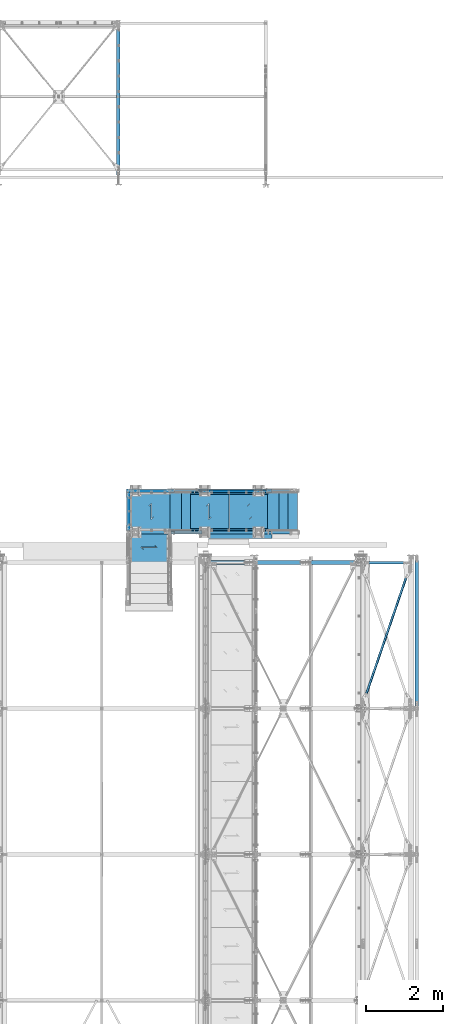
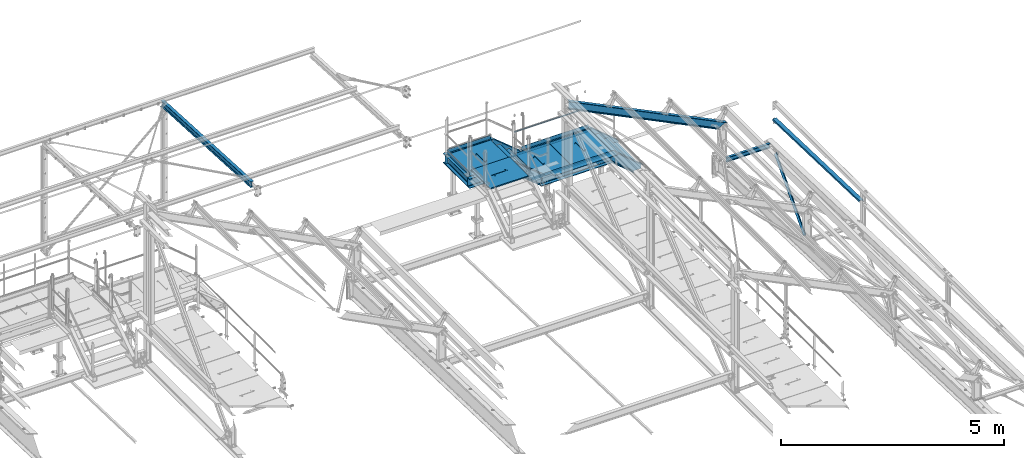
# One storey, part 58 of 496: 25 beams, 5 members, 22 elements without a shape of their own.
"""IFC2X3 building model written with IfcOpenShell, lengths in millimetres."""

import ifcopenshell
import ifcopenshell.guid

model = None  # the IFC model being written
_history = None  # IfcOwnerHistory: only IFC2X3 demands one
_inside = {}  # id of a spatial element -> (the spatial element, [elements in it])
_under = {}  # id of a project, library or spatial element -> (it, [spatial elements below it])
_declared = {}  # id of a project -> (the project, [libraries it declares])
_typed = {}  # id of a type object -> (the type object, [elements of that type])
_made_of = {}  # id of a material, layer set ... -> (it, [elements and type objects made of it])


def new_model(schema):
    """Start an empty IFC model of exactly this schema.

    Asked for "IFC4X3", IfcOpenShell would pick the latest addendum, in which some entities
    have other attributes; the version numbers below select the first issue.
    IFC2X3 requires an IfcOwnerHistory on every rooted entity: one is made here for all.
    """
    global model, _history
    if schema == "IFC4X3":
        model = ifcopenshell.file(schema_version=(4, 3, 0, 0))
    else:
        model = ifcopenshell.file(schema=schema)
    _inside.clear()
    _under.clear()
    _declared.clear()
    _typed.clear()
    _made_of.clear()
    _history = None
    if model.schema == "IFC2X3":
        org = make("IfcOrganization", Name="unknown")
        user = make(
            "IfcPersonAndOrganization",
            ThePerson=make("IfcPerson", FamilyName="unknown"),
            TheOrganization=org,
        )
        app = make(
            "IfcApplication",
            ApplicationDeveloper=org,
            Version="unknown",
            ApplicationFullName="unknown",
            ApplicationIdentifier="unknown",
        )
        _history = make(
            "IfcOwnerHistory",
            OwningUser=user,
            OwningApplication=app,
            ChangeAction="ADDED",
            CreationDate=0,
        )
    return model


def make(cls, **values):
    """One entity of the class cls with the attributes given. An attribute that is None is left unset."""
    return model.create_entity(
        cls, **{name: value for name, value in values.items() if value is not None}
    )


def rooted(cls, **values):
    """An entity with a GlobalId (a new one), such as an element, a storey or a relation."""
    return make(cls, GlobalId=ifcopenshell.guid.new(), OwnerHistory=_history, **values)


def si_unit(unit_type, name, prefix=None):
    """IfcSIUnit, for example si_unit("LENGTHUNIT", "METRE", prefix="MILLI")."""
    return make("IfcSIUnit", UnitType=unit_type, Prefix=prefix, Name=name)


def assignment(units):
    """IfcUnitAssignment: the units of a project."""
    return None if units is None else make("IfcUnitAssignment", Units=units)


def point(xyz):
    """IfcCartesianPoint."""
    return None if xyz is None else make("IfcCartesianPoint", Coordinates=xyz)


def direction(xyz):
    """IfcDirection."""
    return None if xyz is None else make("IfcDirection", DirectionRatios=xyz)


def frame(location, z_axis=None, x_axis=None):
    """IfcAxis2Placement3D, a coordinate frame: its origin and axes. An axis left out is left unset."""
    return make(
        "IfcAxis2Placement3D",
        Location=point(location),
        Axis=direction(z_axis),
        RefDirection=direction(x_axis),
    )


def frame_2d(location, x_axis=None):
    """IfcAxis2Placement2D, a coordinate frame in the plane: its origin and x axis."""
    return make(
        "IfcAxis2Placement2D", Location=point(location), RefDirection=direction(x_axis)
    )


def origin_with_axes():
    """The frame at (0, 0, 0) with the z axis (0, 0, 1) and the x axis (1, 0, 0) written out."""
    return frame((0.0, 0.0, 0.0), z_axis=(0.0, 0.0, 1.0), x_axis=(1.0, 0.0, 0.0))


def origin_2d_with_axis():
    """The frame at (0, 0) in the plane with the x axis (1, 0) written out."""
    return frame_2d((0.0, 0.0), x_axis=(1.0, 0.0))


def place(relative_to, where):
    """IfcLocalPlacement: puts the frame where relative to a parent placement (None: the world)."""
    return make(
        "IfcLocalPlacement", PlacementRelTo=relative_to, RelativePlacement=where
    )


def context(
    kind, dimensions, precision=None, world=None, true_north=None, identifier=None
):
    """IfcGeometricRepresentationContext, for example the 3D "Model" context."""
    return make(
        "IfcGeometricRepresentationContext",
        ContextIdentifier=identifier,
        ContextType=kind,
        CoordinateSpaceDimension=dimensions,
        Precision=precision,
        WorldCoordinateSystem=world,
        TrueNorth=true_north,
    )


def subcontext(parent, identifier, kind, view, scale=None):
    """IfcGeometricRepresentationSubContext, for example "Body" below "Model"."""
    return make(
        "IfcGeometricRepresentationSubContext",
        ContextIdentifier=identifier,
        ContextType=kind,
        ParentContext=parent,
        TargetScale=scale,
        TargetView=view,
    )


def project(units=None, contexts=None):
    """IfcProject with its units and contexts."""
    return rooted(
        "IfcProject",
        Name="project",
        RepresentationContexts=contexts,
        UnitsInContext=assignment(units),
    )


def spatial(cls, under=None, at=None, **own):
    """A site, building, storey or space (cls), placed at a placement, below another one or the project."""
    s = rooted(cls, ObjectPlacement=at, **own)
    if under is not None:
        _under.setdefault(under.id(), (under, []))[1].append(s)
    return s


def polyline(points):
    """IfcPolyline through the points."""
    return make("IfcPolyline", Points=[point(p) for p in points])


def profile(cls, at=None, kind="AREA", **sizes):
    """A parametric profile (cls). Its sizes go by their IFC names, for example OverallWidth=200.0."""
    return make(cls, ProfileType=kind, Position=at, **sizes)


def rectangle(**sizes):
    """IfcRectangleProfileDef."""
    return profile("IfcRectangleProfileDef", **sizes)


def hollow_circle(**sizes):
    """IfcCircleHollowProfileDef."""
    return profile("IfcCircleHollowProfileDef", **sizes)


def i_section(**sizes):
    """IfcIShapeProfileDef."""
    return profile("IfcIShapeProfileDef", **sizes)


def l_section(**sizes):
    """IfcLShapeProfileDef."""
    return profile("IfcLShapeProfileDef", **sizes)


def u_section(**sizes):
    """IfcUShapeProfileDef."""
    return profile("IfcUShapeProfileDef", **sizes)


def outline(outer, holes=None, kind="AREA"):
    """IfcArbitraryClosedProfileDef: a profile drawn as a closed curve; with holes, ...WithVoids."""
    if holes is None:
        return make("IfcArbitraryClosedProfileDef", ProfileType=kind, OuterCurve=outer)
    return make(
        "IfcArbitraryProfileDefWithVoids",
        ProfileType=kind,
        OuterCurve=outer,
        InnerCurves=holes,
    )


def extrude(swept, where, along, depth):
    """IfcExtrudedAreaSolid: the profile swept, set in the frame where, extruded along a direction by depth."""
    return make(
        "IfcExtrudedAreaSolid",
        SweptArea=swept,
        Position=where,
        ExtrudedDirection=direction(along),
        Depth=depth,
    )


def boolean(op, a, b):
    """IfcBooleanResult of two solids."""
    return make("IfcBooleanResult", Operator=op, FirstOperand=a, SecondOperand=b)


def clip(a, b, op="DIFFERENCE"):
    """IfcBooleanClippingResult: the solid a cut by the half space b."""
    return make(
        "IfcBooleanClippingResult", Operator=op, FirstOperand=a, SecondOperand=b
    )


def halfspace(plane, agree):
    """IfcHalfSpaceSolid: all space on one side of the plane z = 0 of the frame plane."""
    return make(
        "IfcHalfSpaceSolid",
        BaseSurface=make("IfcPlane", Position=plane),
        AgreementFlag=agree,
    )


def shape(context_of_items, identifier, shape_type, items):
    """IfcShapeRepresentation: the items that make up one representation, for example the "Body"."""
    return make(
        "IfcShapeRepresentation",
        ContextOfItems=context_of_items,
        RepresentationIdentifier=identifier,
        RepresentationType=shape_type,
        Items=items,
    )


def material(Name=None, Category=None):
    """IfcMaterial."""
    return make("IfcMaterial", Name=Name, Category=Category)


def made_of(thing, what):
    """Note that an element or type object is made of a material, layer set ...; save() writes the relation."""
    if what is not None:
        _made_of.setdefault(what.id(), (what, []))[1].append(thing)
    return thing


def type_object(cls, material=None, **own):
    """A type object (cls), such as IfcWallType, which elements share."""
    return made_of(rooted(cls, **own), material)


def element(
    cls,
    number,
    at=None,
    inside=None,
    cuts=None,
    type_object=None,
    material=None,
    context=None,
    identifier="Body",
    shape_type=None,
    held_by="IfcProductDefinitionShape",
    body=None,
    shapes=None,
    **own,
):
    """One element of the class cls, such as IfcWall. Its Tag is "e" and its number.

    at: its placement. inside: the storey or other place that contains it. cuts: it is an
    opening in that element (IfcRelVoidsElement). A single representation is given by context,
    identifier, shape_type and body (its items); several are given by shapes. held_by: the class
    of the entity that holds the representations. save() writes the other relations.
    """
    e = rooted(cls, Tag="e%d" % number, ObjectPlacement=at, **own)
    if body is not None:
        shapes = [shape(context, identifier, shape_type, body)]
    if shapes is not None:
        e.Representation = make(held_by, Representations=shapes)
    if inside is not None:
        _inside.setdefault(inside.id(), (inside, []))[1].append(e)
    if cuts is not None:
        rooted(
            "IfcRelVoidsElement", RelatingBuildingElement=cuts, RelatedOpeningElement=e
        )
    if type_object is not None:
        _typed.setdefault(type_object.id(), (type_object, []))[1].append(e)
    return made_of(e, material)


def aggregate(whole, parts):
    """IfcRelAggregates: a whole, such as a stair, and the parts it consists of."""
    return rooted("IfcRelAggregates", RelatingObject=whole, RelatedObjects=parts)


def save(model, path):
    """Write the relations noted so far, then the file.

    IfcRelAggregates (storeys below a building ...), IfcRelContainedInSpatialStructure (elements
    in a storey), IfcRelDefinesByType, IfcRelAssociatesMaterial and IfcRelDeclares: one each for
    every whole, place, type object, material and project.
    """
    for whole, parts in _under.values():
        aggregate(whole, parts)
    for where, things in _inside.values():
        rooted(
            "IfcRelContainedInSpatialStructure",
            RelatedElements=things,
            RelatingStructure=where,
        )
    for kind, things in _typed.values():
        rooted("IfcRelDefinesByType", RelatedObjects=things, RelatingType=kind)
    for what, things in _made_of.values():
        rooted("IfcRelAssociatesMaterial", RelatedObjects=things, RelatingMaterial=what)
    for by, libraries in _declared.values():
        rooted("IfcRelDeclares", RelatingContext=by, RelatedDefinitions=libraries)
    model.write(path)


model = new_model("IFC2X3")

# Units and contexts
model_context = context("Model", 3, precision=1e-05, world=origin_with_axes())
body_context = subcontext(model_context, "Body", "Model", "MODEL_VIEW")
ifc_project = project(units=[si_unit("LENGTHUNIT", "METRE", prefix="MILLI"), si_unit("AREAUNIT", "SQUARE_METRE"), si_unit("VOLUMEUNIT", "CUBIC_METRE"), si_unit("MASSUNIT", "GRAM", prefix="KILO"), si_unit("TIMEUNIT", "SECOND"), si_unit("PLANEANGLEUNIT", "RADIAN"), si_unit("SOLIDANGLEUNIT", "STERADIAN"), si_unit("THERMODYNAMICTEMPERATUREUNIT", "DEGREE_CELSIUS"), si_unit("LUMINOUSINTENSITYUNIT", "LUMEN")], contexts=[model_context])

# Site, building, storey
site_placement = place(None, origin_with_axes())
site = spatial("IfcSite", under=ifc_project, at=site_placement, CompositionType="ELEMENT")
building_placement = place(site_placement, origin_with_axes())
building = spatial("IfcBuilding", under=site, at=building_placement, Name="Undefined", CompositionType="ELEMENT")
storey_placement = place(building_placement, origin_with_axes())
storey = spatial("IfcBuildingStorey", under=building, at=storey_placement, Name="Undefined", CompositionType="ELEMENT", Elevation=0.0)

# Assembly, beam
assembly_1_placement = place(storey_placement, origin_with_axes())
assembly_1 = element("IfcElementAssembly", 1, at=assembly_1_placement, inside=storey, Name="VIDE", AssemblyPlace="NOTDEFINED", PredefinedType="NOTDEFINED")
ifc_material_1 = material(Name="Undefined/S235-E24")
beam_type_1 = type_object("IfcBeamType", PredefinedType="NOTDEFINED")
beam_1_placement = place(assembly_1_placement, frame((36000.0099902533, 15929.9998774163, 8112.9999407383), z_axis=(0.0, -1.0, 0.0), x_axis=(-1.0, 0.0, 0.0)))
beam_1 = element("IfcBeam", 2, at=beam_1_placement, type_object=beam_type_1, material=ifc_material_1, Name="VIDE", context=body_context, shape_type="SweptSolid", body=[
    extrude(rectangle(XDim=6.0, YDim=200.0, at=origin_2d_with_axis()), frame((1650.0, 0.0, 0.0), z_axis=(-1.0, 0.0, 0.0), x_axis=(0.0, -1.0, 0.0)), (0.0, 0.0, 1.0), 1650.0),
])
aggregate(assembly_1, [beam_1])

# Assembly, beams
assembly_2_placement = place(storey_placement, origin_with_axes())
assembly_2 = element("IfcElementAssembly", 3, at=assembly_2_placement, inside=storey, Name="MAIN COURANTE", AssemblyPlace="NOTDEFINED", PredefinedType="NOTDEFINED")
beam_type_2 = type_object("IfcBeamType", PredefinedType="NOTDEFINED")
beam_2_placement = place(assembly_2_placement, frame((34050.3145397259, 17089.9937511109, 8653.80000001012), z_axis=(0.0, 1.0, 0.0), x_axis=(1.0, 0.0, 0.0)))
beam_2 = element("IfcBeam", 4, at=beam_2_placement, type_object=beam_type_2, material=ifc_material_1, Name="LISSE", context=body_context, shape_type="Clipping", body=[
    clip(clip(extrude(hollow_circle(Radius=10.64999962, WallThickness=2.0, at=origin_2d_with_axis()), frame((1828.74844172951, -1.81898940354586e-12, 0.0), z_axis=(-1.0, 0.0, 0.0), x_axis=(0.0, -1.0, 0.0)), (0.0, 0.0, 1.0), 1836.49), halfspace(frame((1821.00987948852, 4.36557456851006e-10, -0.00100506085436791), z_axis=(0.940271589914334, 0.340425229969278, -5.78267025161579e-07), x_axis=(0.0, 0.0, 1.0)), False)), halfspace(frame((3.80609846943116, -10.6499996200018, 0.000112519468530081), z_axis=(0.941671113820088, 0.336534564935759, -5.79127732359695e-07), x_axis=(0.0, 0.0, 1.0)), True)),
])
beam_type_3 = type_object("IfcBeamType", PredefinedType="NOTDEFINED")
beam_3_placement = place(assembly_2_placement, frame((35944.9962475594, 17057.481480291, 8170.00000001012), z_axis=(0.0, 0.0, -1.0), x_axis=(-1.0, 0.0, 0.0)))
beam_3 = element("IfcBeam", 5, at=beam_3_placement, type_object=beam_type_3, material=ifc_material_1, context=body_context, shape_type="SweptSolid", body=[
    extrude(rectangle(XDim=5.0, YDim=100.0, at=origin_2d_with_axis()), frame((1734.99407492106, 0.0, 0.0), z_axis=(-1.0, 0.0, 0.0), x_axis=(0.0, -1.0, 0.0)), (0.0, 0.0, 1.0), 1734.99),
])
beam_4_placement = place(assembly_2_placement, frame((33404.9962475594, 17057.481480291, 8760.00000001012), z_axis=(0.0, 0.0, -1.0), x_axis=(-1.0, 0.0, 0.0)))
beam_4 = element("IfcBeam", 6, at=beam_4_placement, type_object=beam_type_3, material=ifc_material_1, context=body_context, shape_type="SweptSolid", body=[
    extrude(rectangle(XDim=5.0, YDim=100.0, at=origin_2d_with_axis()), frame((1100.00006264001, 0.0, 0.0), z_axis=(-1.0, 0.0, 0.0), x_axis=(0.0, -1.0, 0.0)), (0.0, 0.0, 1.0), 1100.0),
])
aggregate(assembly_2, [beam_2, beam_3, beam_4])

# Assembly, beam
assembly_3_placement = place(storey_placement, origin_with_axes())
assembly_3 = element("IfcElementAssembly", 7, at=assembly_3_placement, inside=storey, Name="MAIN COURANTE", AssemblyPlace="NOTDEFINED", PredefinedType="NOTDEFINED")
beam_5_placement = place(assembly_3_placement, frame((32282.4987221813, 17044.9977309424, 8760.00000001012), z_axis=(0.0, 0.0, -1.0), x_axis=(0.0, -1.0, 0.0)))
beam_5 = element("IfcBeam", 8, at=beam_5_placement, type_object=beam_type_3, material=ifc_material_1, context=body_context, shape_type="SweptSolid", body=[
    extrude(rectangle(XDim=5.0, YDim=100.0, at=origin_2d_with_axis()), frame((1009.99407492107, 0.0, 0.0), z_axis=(-1.0, 0.0, 0.0), x_axis=(0.0, -1.0, 0.0)), (0.0, 0.0, 1.0), 1009.99),
])
aggregate(assembly_3, [beam_5])

assembly_4_placement = place(storey_placement, origin_with_axes())
assembly_4 = element("IfcElementAssembly", 9, at=assembly_4_placement, inside=storey, Name="PALIER", AssemblyPlace="NOTDEFINED", PredefinedType="NOTDEFINED")
beam_type_4 = type_object("IfcBeamType", PredefinedType="NOTDEFINED")
beam_6_placement = place(assembly_4_placement, frame((35944.9999902344, 16530.0012856021, 8094.9999407569), z_axis=(0.0, 1.0, 0.0), x_axis=(-1.0, 0.0, 0.0)))
beam_6 = element("IfcBeam", 10, at=beam_6_placement, type_object=beam_type_4, material=ifc_material_1, Name="PALIER", context=body_context, shape_type="CSG", body=[
    boolean("DIFFERENCE", extrude(rectangle(XDim=30.0, YDim=990.0, at=origin_2d_with_axis()), frame((1050.0, 0.0, 0.0), z_axis=(-1.0, 0.0, 0.0), x_axis=(0.0, -1.0, 0.0)), (0.0, 0.0, 1.0), 1050.0), extrude(outline(polyline([(0.0, 0.0), (87.0678024292865, -7.27595761418343e-12), (-195.774902343946, 282.842712402629), (-132.842712402475, 282.842712402631), (-132.842712402482, 292.84271240264), (-219.917037964085, 292.84271240264), (62.9256706238448, 10.0000000000091), (-1.81898940354586e-10, 10.0000000000073), (0.0, 0.0)])), frame((468.433764126472, 17.5, -150.504124684554), z_axis=(0.0, -1.0, 0.0), x_axis=(0.707106781186548, 0.0, -0.707106781186548)), (0.0, 0.0, 1.0), 35.0)),
])
aggregate(assembly_4, [beam_6])

assembly_5_placement = place(storey_placement, origin_with_axes())
assembly_5 = element("IfcElementAssembly", 11, at=assembly_5_placement, inside=storey, Name="PALIER", AssemblyPlace="NOTDEFINED", PredefinedType="NOTDEFINED")
beam_7_placement = place(assembly_5_placement, frame((33404.9999902344, 16530.0012856021, 8685.0), z_axis=(0.0, 1.0, 0.0), x_axis=(-1.0, 0.0, 0.0)))
beam_7 = element("IfcBeam", 12, at=beam_7_placement, type_object=beam_type_4, material=ifc_material_1, Name="PALIER", context=body_context, shape_type="CSG", body=[
    boolean("DIFFERENCE", extrude(rectangle(XDim=30.0, YDim=990.0, at=origin_2d_with_axis()), frame((1090.0, 0.0, 0.0), z_axis=(-1.0, 0.0, 0.0), x_axis=(0.0, -1.0, 0.0)), (0.0, 0.0, 1.0), 1090.0), extrude(outline(polyline([(0.0, 0.0), (87.0678024292865, -7.27595761418343e-12), (-195.774902343946, 282.842712402629), (-132.842712402475, 282.842712402631), (-132.842712402482, 292.84271240264), (-219.917037964085, 292.84271240264), (62.9256706238448, 10.0000000000091), (-1.81898940354586e-10, 10.0000000000073), (0.0, 0.0)])), frame((488.433762432338, 17.4998126435639, -150.504124684554), z_axis=(0.0, -1.0, 0.0), x_axis=(0.707106781186548, 0.0, -0.707106781186548)), (0.0, 0.0, 1.0), 35.0)),
])
aggregate(assembly_5, [beam_7])

assembly_6_placement = place(storey_placement, origin_with_axes())
assembly_6 = element("IfcElementAssembly", 13, at=assembly_6_placement, inside=storey, Name="PALIER", AssemblyPlace="NOTDEFINED", PredefinedType="NOTDEFINED")
beam_8_placement = place(assembly_6_placement, frame((34884.9999902344, 16530.0012856021, 8094.9999407569), z_axis=(0.0, 1.0, 0.0), x_axis=(-1.0, 0.0, 0.0)))
beam_8 = element("IfcBeam", 14, at=beam_8_placement, type_object=beam_type_4, material=ifc_material_1, Name="PALIER", context=body_context, shape_type="CSG", body=[
    boolean("DIFFERENCE", extrude(rectangle(XDim=30.0, YDim=990.0, at=origin_2d_with_axis()), frame((1050.0, 0.0, 0.0), z_axis=(-1.0, 0.0, 0.0), x_axis=(0.0, -1.0, 0.0)), (0.0, 0.0, 1.0), 1050.0), extrude(outline(polyline([(0.0, 0.0), (87.0678024292865, -7.27595761418343e-12), (-195.774902343946, 282.842712402629), (-132.842712402475, 282.842712402631), (-132.842712402482, 292.84271240264), (-219.917037964085, 292.84271240264), (62.9256706238448, 10.0000000000091), (-1.81898940354586e-10, 10.0000000000073), (0.0, 0.0)])), frame((468.433764126472, 17.5, -150.504124684554), z_axis=(0.0, -1.0, 0.0), x_axis=(0.707106781186548, 0.0, -0.707106781186548)), (0.0, 0.0, 1.0), 35.0)),
])
aggregate(assembly_6, [beam_8])

assembly_7_placement = place(storey_placement, origin_with_axes())
assembly_7 = element("IfcElementAssembly", 15, at=assembly_7_placement, inside=storey, Name="PALIER", AssemblyPlace="NOTDEFINED", PredefinedType="NOTDEFINED")
beam_9_placement = place(assembly_7_placement, frame((32809.9938089558, 16020.0036221498, 8865.0), z_axis=(-1.0, 0.0, 0.0), x_axis=(0.0, -1.0, 0.0)))
beam_9 = element("IfcBeam", 16, at=beam_9_placement, type_object=beam_type_4, material=ifc_material_1, Name="PALIER", context=body_context, shape_type="CSG", body=[
    boolean("DIFFERENCE", extrude(rectangle(XDim=30.0, YDim=990.0, at=origin_2d_with_axis()), frame((845.00383109971, 0.0, 0.0), z_axis=(-1.0, 0.0, 0.0), x_axis=(0.0, -1.0, 0.0)), (0.0, 0.0, 1.0), 845.0), extrude(outline(polyline([(0.0, 0.0), (87.0678024292865, -7.27595761418343e-12), (-195.774902343946, 282.842712402629), (-132.842712402475, 282.842712402631), (-132.842712402482, 292.84271240264), (-219.917037964085, 292.84271240264), (62.9256706238448, 10.0000000000091), (-1.81898940354586e-10, 10.0000000000073), (0.0, 0.0)])), frame((365.940460299036, 17.4998126435639, -150.5094572854), z_axis=(0.0, -1.0, 0.0), x_axis=(0.707106781186548, 0.0, -0.707106781186548)), (0.0, 0.0, 1.0), 35.0)),
])
aggregate(assembly_7, [beam_9])

assembly_8_placement = place(storey_placement, origin_with_axes())
assembly_8 = element("IfcElementAssembly", 17, at=assembly_8_placement, inside=storey, Name="SUPPORT", AssemblyPlace="NOTDEFINED", PredefinedType="NOTDEFINED")
beam_type_5 = type_object("IfcBeamType", PredefinedType="NOTDEFINED")
beam_10_placement = place(assembly_8_placement, frame((35894.9999902344, 17004.9999136338, 8054.9999407569), z_axis=(0.0, 0.0, -1.0), x_axis=(-1.0, 0.0, 0.0)))
beam_10 = element("IfcBeam", 18, at=beam_10_placement, type_object=beam_type_5, material=ifc_material_1, Name="SUPPORT", context=body_context, shape_type="SweptSolid", body=[
    extrude(l_section(Depth=50.0, Width=50.0, Thickness=5.0, FilletRadius=7.0, EdgeRadius=3.5, at=origin_2d_with_axis()), frame((2009.99999989913, 0.0, 0.0), z_axis=(-1.0, 0.0, 0.0), x_axis=(0.0, -1.0, 0.0)), (0.0, 0.0, 1.0), 2010.0),
])
aggregate(assembly_8, [beam_10])

assembly_9_placement = place(storey_placement, origin_with_axes())
assembly_9 = element("IfcElementAssembly", 19, at=assembly_9_placement, inside=storey, Name="SUPPORT", AssemblyPlace="NOTDEFINED", PredefinedType="NOTDEFINED")
beam_11_placement = place(assembly_9_placement, frame((33884.9999903353, 16054.9996684663, 8054.9999407569), z_axis=(0.0, 0.0, -1.0), x_axis=(1.0, 0.0, 0.0)))
beam_11 = element("IfcBeam", 20, at=beam_11_placement, type_object=beam_type_5, material=ifc_material_1, Name="SUPPORT", context=body_context, shape_type="SweptSolid", body=[
    extrude(l_section(Depth=50.0, Width=50.0, Thickness=5.0, FilletRadius=7.0, EdgeRadius=3.5, at=origin_2d_with_axis()), frame((2009.99999989913, 0.0, 0.0), z_axis=(-1.0, 0.0, 0.0), x_axis=(0.0, -1.0, 0.0)), (0.0, 0.0, 1.0), 2010.0),
])
aggregate(assembly_9, [beam_11])

# Assembly, member
assembly_10_placement = place(storey_placement, origin_with_axes())
assembly_10 = element("IfcElementAssembly", 21, at=assembly_10_placement, inside=storey, AssemblyPlace="NOTDEFINED", PredefinedType="NOTDEFINED")
ifc_material_2 = material(Name="Undefined/S275-E28")
member_type_1 = type_object("IfcMemberType", Name="UPN260", PredefinedType="NOTDEFINED")
member_1_placement = place(assembly_10_placement, frame((34103.6359782149, 15984.9996684876, 8009.44650543934), z_axis=(-0.63380948681209, 0.0, -0.77348919477068), x_axis=(-0.773488973625643, 0.0, 0.633809756693245)))
member_1 = element("IfcMember", 22, at=member_1_placement, type_object=member_type_1, material=ifc_material_2, ObjectType="UPN260", context=body_context, shape_type="Clipping", body=[
    clip(clip(extrude(u_section(Depth=260.0, FlangeWidth=90.0, WebThickness=10.0, FlangeThickness=14.0, FilletRadius=14.0, EdgeRadius=7.0, FlangeSlope=0.0798299857122373, at=origin_2d_with_axis()), frame((1123.44862759556, -1.81898940354586e-12, 0.0), z_axis=(-1.0, 0.0, 0.0), x_axis=(0.0, -1.0, 0.0)), (0.0, 0.0, 1.0), 1408.94), halfspace(frame((930.878776339017, 45.006178684931, -130.000000001099), z_axis=(0.941671627125962, 0.0, 0.336533128630664), x_axis=(0.0, -1.0, 0.0)), False)), halfspace(frame((-1.09252141555771e-07, 44.9999999787524, -129.999999907814), z_axis=(-0.941673964012416, 0.0, -0.336526589590099), x_axis=(0.0, 1.0, 0.0)), False)),
])

assembly_11_placement = place(storey_placement, origin_with_axes())
assembly_11 = element("IfcElementAssembly", 23, at=assembly_11_placement, inside=storey, AssemblyPlace="NOTDEFINED", PredefinedType="NOTDEFINED")
member_2_placement = place(assembly_11_placement, frame((33383.6110682815, 17074.9958074295, 8599.44642100542), z_axis=(-0.633810576130833, -1.31300000066403e-06, -0.773488302162985), x_axis=(0.773488302161326, 1.60200000082118e-06, -0.633810576132193)))
member_2 = element("IfcMember", 24, at=member_2_placement, type_object=member_type_1, material=ifc_material_2, ObjectType="UPN260", context=body_context, shape_type="Clipping", body=[
    clip(clip(extrude(u_section(Depth=260.0, FlangeWidth=90.0, WebThickness=10.0, FlangeThickness=14.0, FilletRadius=14.0, EdgeRadius=7.0, FlangeSlope=0.0798299857122373, at=origin_2d_with_axis()), frame((1216.36733735445, -2.10852457610342e-19, -3.63797880709171e-12), z_axis=(-1.0, 0.0, 0.0), x_axis=(0.0, -1.0, 0.0)), (0.0, 0.0, 1.0), 1408.94), halfspace(frame((930.877174444748, 1044.99780092066, -129.999997853567), z_axis=(0.941673490072606, 1.95042208498579e-06, -0.336527915767285), x_axis=(1.60200000027544e-06, -0.999999999997855, -1.31300000066404e-06)), False)), halfspace(frame((92.9171561234361, 1044.99611712716, 130.001182169719), z_axis=(-0.941671044923155, -1.95042715133223e-06, 0.336534757713865), x_axis=(1.60200000027544e-06, -0.999999999997855, -1.31300000066404e-06)), False)),
])

# Member
member_3_placement = place(assembly_10_placement, frame((36799.7706127592, 15984.9996684857, 7278.46901234049), z_axis=(-0.640184399664481, 0.0, -0.768221279597375), x_axis=(-0.768221279597376, 0.0, 0.640184399664479)))
member_3 = element("IfcMember", 25, at=member_3_placement, type_object=member_type_1, material=ifc_material_2, ObjectType="UPN260", context=body_context, shape_type="Clipping", body=[
    clip(clip(clip(extrude(u_section(Depth=260.0, FlangeWidth=90.0, WebThickness=10.0, FlangeThickness=14.0, FilletRadius=14.0, EdgeRadius=7.0, FlangeSlope=0.0798299857122373, at=origin_2d_with_axis()), frame((1237.09223205228, 1.81898940354586e-12, -3.70665122107218e-12), z_axis=(-1.0, 0.0, 0.0), x_axis=(0.0, -1.0, 0.0)), (0.0, 0.0, 1.0), 1237.09), halfspace(frame((245.689170201924, 45.0000000000891, -149.914659340717), z_axis=(-0.768221279597375, 0.0, -0.640184399664481), x_axis=(0.0, 1.0, 0.0)), False)), halfspace(frame((-72.2625156967988, 45.0000000000891, -189.778996649024), z_axis=(-0.640184399664479, 0.0, 0.768221279597377), x_axis=(0.0, 1.0, 0.0)), False)), halfspace(frame((1048.75984968731, 45.0000000018499, 130.000000000287), z_axis=(0.940271577725442, 0.0, 0.340425263636099), x_axis=(0.0, 1.0, 0.0)), False)),
])

member_4_placement = place(assembly_11_placement, frame((35921.7760183, 17074.9996684893, 8010.13117439031), z_axis=(-0.640184399664481, 0.0, -0.768221279597375), x_axis=(0.768221279597365, 0.0, -0.640184399664493)))
member_4 = element("IfcMember", 26, at=member_4_placement, type_object=member_type_1, material=ifc_material_2, ObjectType="UPN260", context=body_context, shape_type="Clipping", body=[
    clip(clip(clip(extrude(u_section(Depth=260.0, FlangeWidth=90.0, WebThickness=10.0, FlangeThickness=14.0, FilletRadius=14.0, EdgeRadius=7.0, FlangeSlope=0.0798299857122373, at=origin_2d_with_axis()), frame((1142.89283280672, 0.0, 1.26886593766109e-13), z_axis=(-1.0, 0.0, 0.0), x_axis=(0.0, -1.0, 0.0)), (0.0, 0.0, 1.0), 1237.09), halfspace(frame((897.20366260222, 45.0, -149.914659340382), z_axis=(0.768221279597365, 0.0, -0.640184399664493), x_axis=(0.64018434015628, 0.0, 0.768221329187538)), False)), halfspace(frame((1215.15534850094, 45.0, -189.778996648689), z_axis=(0.64018434015628, 0.0, 0.768221329187538), x_axis=(-0.768221279597376, 0.0, 0.640184399664479)), False)), halfspace(frame((94.1329831168296, 1045.00000000176, 130.000000000626), z_axis=(-0.940271577725442, 0.0, 0.340425263636099), x_axis=(0.0, -1.0, 0.0)), False)),
])

# Beam
beam_type_6 = type_object("IfcBeamType", Name="UPN260", PredefinedType="NOTDEFINED")
beam_12_placement = place(assembly_10_placement, frame((33466.0064595263, 15985.0036039866, 8570.00016502355), z_axis=(0.0, 0.0, -1.0), x_axis=(-0.999999999997803, 2.09199999990344e-06, -1.31999999818056e-07)))
beam_12 = element("IfcBeam", 27, at=beam_12_placement, type_object=beam_type_6, material=ifc_material_2, ObjectType="UPN260", context=body_context, shape_type="Clipping", body=[
    clip(extrude(u_section(Depth=260.0, FlangeWidth=90.0, WebThickness=10.0, FlangeThickness=14.0, FilletRadius=14.0, EdgeRadius=7.0, FlangeSlope=0.0798299857122373, at=origin_2d_with_axis()), frame((1246.0141922961, -3.56254158220676e-20, -1.81898940354586e-12), z_axis=(-1.0, 0.0, 0.0), x_axis=(0.0, -1.0, 0.0)), (0.0, 0.0, 1.0), 1246.48), halfspace(frame((0.00209211195033276, 1044.9963096451, -129.999999572146), z_axis=(-0.941670781986072, 1.96997527822525e-06, 0.336535493447361), x_axis=(0.336535493446625, -7.04032252849813e-07, 0.941670781988133)), False)),
])

beam_13_placement = place(assembly_11_placement, frame((32219.9922672322, 17074.9933718455, 8570.00000000275), z_axis=(0.0, 0.0, -1.0), x_axis=(0.999999999997803, 2.09200000135276e-06, 1.31999999817392e-07)))
beam_13 = element("IfcBeam", 28, at=beam_13_placement, type_object=beam_type_6, material=ifc_material_2, ObjectType="UPN260", context=body_context, shape_type="Clipping", body=[
    clip(extrude(u_section(Depth=260.0, FlangeWidth=90.0, WebThickness=10.0, FlangeThickness=14.0, FilletRadius=14.0, EdgeRadius=7.0, FlangeSlope=0.0798299857122373, at=origin_2d_with_axis()), frame((1246.47920182386, 3.56387423911291e-20, -1.81898940354586e-12), z_axis=(-1.0, 0.0, 0.0), x_axis=(0.0, -1.0, 0.0)), (0.0, 0.0, 1.0), 1246.48), halfspace(frame((1246.01210018487, 1044.99631003873, -130.000000119073), z_axis=(0.941670781986074, 1.96997527822525e-06, 0.336535493447357), x_axis=(1.15500000027281e-06, -0.999999999999333, 0.0)), False)),
])

beam_14_placement = place(assembly_11_placement, frame((34186.0289487381, 17074.9974696588, 7980.00020022042), z_axis=(0.0, 0.0, -1.0), x_axis=(0.999999999999259, 1.20900000090028e-06, -1.42999999767771e-07)))
beam_14 = element("IfcBeam", 29, at=beam_14_placement, type_object=beam_type_6, material=ifc_material_2, ObjectType="UPN260", context=body_context, shape_type="Clipping", body=[
    clip(clip(extrude(u_section(Depth=260.0, FlangeWidth=90.0, WebThickness=10.0, FlangeThickness=14.0, FilletRadius=14.0, EdgeRadius=7.0, FlangeSlope=0.0798299857122373, at=origin_2d_with_axis()), frame((1866.36594337937, -9.86806740857558e-20, 4.94022951773652e-20), z_axis=(-1.0, 0.0, 0.0), x_axis=(0.0, -1.0, 0.0)), (0.0, 0.0, 1.0), 2007.29), halfspace(frame((1818.9697595243, 1045.00000030639, -130.000000630604), z_axis=(0.940271626320907, 1.13678839794924e-06, 0.340425129411072), x_axis=(1.15500000027281e-06, -0.999999999999333, 0.0)), False)), halfspace(frame((-0.00120920079643838, 1044.99780119173, -130.000000000043), z_axis=(0.94167098396584, 1.13848022134454e-06, 0.336534928284585), x_axis=(1.15500000027281e-06, -0.999999999999333, 0.0)), True)),
])

aggregate(assembly_11, [member_2, beam_13, member_4, beam_14])

# Assembly, beam
assembly_12_placement = place(storey_placement, origin_with_axes())
assembly_12 = element("IfcElementAssembly", 30, at=assembly_12_placement, inside=storey, AssemblyPlace="NOTDEFINED", PredefinedType="NOTDEFINED")
beam_15_placement = place(assembly_12_placement, frame((32265.0061849203, 16034.9999492742, 8570.0), z_axis=(0.0, 0.0, -1.0), x_axis=(-6.26399999950979e-06, 0.999999999980381, -3.63797880701241e-15)))
beam_15 = element("IfcBeam", 31, at=beam_15_placement, type_object=beam_type_6, material=ifc_material_2, ObjectType="UPN260", context=body_context, shape_type="SweptSolid", body=[
    extrude(u_section(Depth=260.0, FlangeWidth=90.0, WebThickness=10.0, FlangeThickness=14.0, FilletRadius=14.0, EdgeRadius=7.0, FlangeSlope=0.0798299857122373, at=origin_2d_with_axis()), frame((989.993334906396, 8.38556972227878e-19, 1.81898940354586e-12), z_axis=(-1.0, 0.0, 0.0), x_axis=(0.0, -1.0, 0.0)), (0.0, 0.0, 1.0), 989.99),
])
aggregate(assembly_12, [beam_15])

# Beam
beam_16_placement = place(assembly_10_placement, frame((36004.9999788016, 15984.9996684876, 7979.99994075731), z_axis=(0.0, 0.0, -1.0), x_axis=(-1.0, 0.0, 0.0)))
beam_16 = element("IfcBeam", 32, at=beam_16_placement, type_object=beam_type_6, material=ifc_material_2, ObjectType="UPN260", context=body_context, shape_type="Clipping", body=[
    clip(clip(extrude(u_section(Depth=260.0, FlangeWidth=90.0, WebThickness=10.0, FlangeThickness=14.0, FilletRadius=14.0, EdgeRadius=7.0, FlangeSlope=0.0798299857122373, at=origin_2d_with_axis()), frame((1959.89175727764, 0.0, 0.0), z_axis=(-1.0, 0.0, 0.0), x_axis=(0.0, -1.0, 0.0)), (0.0, 0.0, 1.0), 2007.29), halfspace(frame((1818.97096871192, 44.9999999787542, -130.000099393701), z_axis=(-0.941670965457109, 0.0, 0.336534980076479), x_axis=(0.0, 1.0, 0.0)), True)), halfspace(frame((-1.09252141555771e-07, 44.9999999787524, -129.999999907814), z_axis=(-0.940271577725442, 0.0, 0.340425263636099), x_axis=(0.0, 1.0, 0.0)), False)),
])

aggregate(assembly_10, [beam_12, member_1, member_3, beam_16])

# Assembly, beam
assembly_13_placement = place(storey_placement, origin_with_axes())
assembly_13 = element("IfcElementAssembly", 33, at=assembly_13_placement, inside=storey, Name="MARCHE", AssemblyPlace="NOTDEFINED", PredefinedType="NOTDEFINED")
beam_type_7 = type_object("IfcBeamType", PredefinedType="NOTDEFINED")
beam_17_placement = place(assembly_13_placement, frame((36664.9999902344, 16530.0012856021, 7495.0), z_axis=(0.0, 1.0, 0.0), x_axis=(-1.0, 0.0, 0.0)))
beam_17 = element("IfcBeam", 34, at=beam_17_placement, type_object=beam_type_7, material=ifc_material_1, Name="MARCHE", context=body_context, shape_type="SweptSolid", body=[
    extrude(rectangle(XDim=30.0, YDim=994.0, at=origin_2d_with_axis()), frame((290.0, 0.0, 0.0), z_axis=(-1.0, 0.0, 0.0), x_axis=(0.0, -1.0, 0.0)), (0.0, 0.0, 1.0), 290.0),
])
aggregate(assembly_13, [beam_17])

assembly_14_placement = place(storey_placement, origin_with_axes())
assembly_14 = element("IfcElementAssembly", 35, at=assembly_14_placement, inside=storey, Name="MARCHE", AssemblyPlace="NOTDEFINED", PredefinedType="NOTDEFINED")
beam_18_placement = place(assembly_14_placement, frame((36424.9999902344, 16530.0012856021, 7695.0), z_axis=(0.0, 1.0, 0.0), x_axis=(-1.0, 0.0, 0.0)))
beam_18 = element("IfcBeam", 36, at=beam_18_placement, type_object=beam_type_7, material=ifc_material_1, Name="MARCHE", context=body_context, shape_type="SweptSolid", body=[
    extrude(rectangle(XDim=30.0, YDim=994.0, at=origin_2d_with_axis()), frame((290.0, 0.0, 0.0), z_axis=(-1.0, 0.0, 0.0), x_axis=(0.0, -1.0, 0.0)), (0.0, 0.0, 1.0), 290.0),
])
aggregate(assembly_14, [beam_18])

assembly_15_placement = place(storey_placement, origin_with_axes())
assembly_15 = element("IfcElementAssembly", 37, at=assembly_15_placement, inside=storey, Name="MARCHE", AssemblyPlace="NOTDEFINED", PredefinedType="NOTDEFINED")
beam_19_placement = place(assembly_15_placement, frame((33884.9999902344, 16530.0012856021, 8291.6699407569), z_axis=(0.0, 1.0, 0.0), x_axis=(-1.0, 0.0, 0.0)))
beam_19 = element("IfcBeam", 38, at=beam_19_placement, type_object=beam_type_7, material=ifc_material_1, Name="MARCHE", context=body_context, shape_type="SweptSolid", body=[
    extrude(rectangle(XDim=30.0, YDim=994.0, at=origin_2d_with_axis()), frame((290.0, 0.0, 0.0), z_axis=(-1.0, 0.0, 0.0), x_axis=(0.0, -1.0, 0.0)), (0.0, 0.0, 1.0), 290.0),
])
aggregate(assembly_15, [beam_19])

assembly_16_placement = place(storey_placement, origin_with_axes())
assembly_16 = element("IfcElementAssembly", 39, at=assembly_16_placement, inside=storey, Name="MARCHE", AssemblyPlace="NOTDEFINED", PredefinedType="NOTDEFINED")
beam_20_placement = place(assembly_16_placement, frame((33644.9999902344, 16530.0012856021, 8488.3299407569), z_axis=(0.0, 1.0, 0.0), x_axis=(-1.0, 0.0, 0.0)))
beam_20 = element("IfcBeam", 40, at=beam_20_placement, type_object=beam_type_7, material=ifc_material_1, Name="MARCHE", context=body_context, shape_type="SweptSolid", body=[
    extrude(rectangle(XDim=30.0, YDim=994.0, at=origin_2d_with_axis()), frame((290.0, 0.0, 0.0), z_axis=(-1.0, 0.0, 0.0), x_axis=(0.0, -1.0, 0.0)), (0.0, 0.0, 1.0), 290.0),
])
aggregate(assembly_16, [beam_20])

assembly_17_placement = place(storey_placement, origin_with_axes())
assembly_17 = element("IfcElementAssembly", 41, at=assembly_17_placement, inside=storey, Name="MARCHE", AssemblyPlace="NOTDEFINED", PredefinedType="NOTDEFINED")
beam_21_placement = place(assembly_17_placement, frame((36184.9999902344, 16530.0012856021, 7894.9999407569), z_axis=(0.0, 1.0, 0.0), x_axis=(-1.0, 0.0, 0.0)))
beam_21 = element("IfcBeam", 42, at=beam_21_placement, type_object=beam_type_7, material=ifc_material_1, Name="MARCHE", context=body_context, shape_type="SweptSolid", body=[
    extrude(rectangle(XDim=30.0, YDim=994.0, at=origin_2d_with_axis()), frame((290.0, 0.0, 0.0), z_axis=(-1.0, 0.0, 0.0), x_axis=(0.0, -1.0, 0.0)), (0.0, 0.0, 1.0), 290.0),
])
aggregate(assembly_17, [beam_21])

assembly_18_placement = place(storey_placement, origin_with_axes())
assembly_18 = element("IfcElementAssembly", 43, at=assembly_18_placement, inside=storey, AssemblyPlace="NOTDEFINED", PredefinedType="NOTDEFINED")
beam_type_8 = type_object("IfcBeamType", PredefinedType="NOTDEFINED")
beam_22_placement = place(assembly_18_placement, frame((38332.8386386372, 11398.0865719882, 7601.7526957008), z_axis=(-0.946212870484427, 0.323385093165564, -0.0101629350051891), x_axis=(0.323544720976448, 0.945746017931154, -0.0297200789978366)))
beam_22 = element("IfcBeam", 44, at=beam_22_placement, type_object=beam_type_8, material=ifc_material_1, context=body_context, shape_type="Clipping", body=[
    clip(clip(extrude(l_section(Depth=60.0, Width=60.0, Thickness=6.0, FilletRadius=8.0, EdgeRadius=4.0, at=origin_2d_with_axis()), frame((3749.34878037932, -9.22502868470826e-13, -1.52236200886338e-13), z_axis=(-1.0, 0.0, 0.0), x_axis=(0.0, -1.0, 0.0)), (0.0, 0.0, 1.0), 3480.71), halfspace(frame((3710.2642422498, -59.9981629879758, -29.9999664171992), z_axis=(0.999999999999259, 1.20900000090028e-06, -1.42999999767771e-07), x_axis=(1.15500000027281e-06, -0.999999999999333, 0.0)), False)), halfspace(frame((307.727643831524, -60.0021751656986, 30.0000340420556), z_axis=(-0.99999999999782, -2.08799998896818e-06, 0.0), x_axis=(1.15500000027281e-06, -0.999999999999333, 0.0)), False)),
])
aggregate(assembly_18, [beam_22])

assembly_19_placement = place(storey_placement, origin_with_axes())
assembly_19 = element("IfcElementAssembly", 45, at=assembly_19_placement, inside=storey, Name="LISSE", AssemblyPlace="NOTDEFINED", PredefinedType="NOTDEFINED")
beam_type_9 = type_object("IfcBeamType", PredefinedType="NOTDEFINED")
beam_23_placement = place(assembly_19_placement, frame((39775.0000000142, 11399.6436312017, 8171.98873515493), z_axis=(1.0, 0.0, 0.0), x_axis=(0.0, 0.999506556345274, -0.0314108870109058)))
beam_23 = element("IfcBeam", 46, at=beam_23_placement, type_object=beam_type_9, material=ifc_material_1, Name="LISSE", context=body_context, shape_type="Clipping", body=[
    clip(clip(extrude(u_section(Depth=100.0, FlangeWidth=50.0, WebThickness=4.0, FlangeThickness=4.0, at=origin_2d_with_axis()), frame((3964.0890563385, -2.75063933875726e-14, 0.0), z_axis=(-1.0, 0.0, 0.0), x_axis=(0.0, -1.0, 0.0)), (0.0, 0.0, 1.0), 3900.38), halfspace(frame((3960.76719072661, 47.1525613632712, -77.5000000134823), z_axis=(-0.999390827384946, -0.0348994862259295, 0.0), x_axis=(0.0, 0.0, 1.0)), True)), halfspace(frame((63.4708632257971, 61.0244601595405, 49.9999999858046), z_axis=(-0.999506560367823, -0.0314107590115635, 0.0), x_axis=(0.0, 0.0, 1.0)), False)),
])
aggregate(assembly_19, [beam_23])

assembly_20_placement = place(storey_placement, origin_with_axes())
assembly_20 = element("IfcElementAssembly", 47, at=assembly_20_placement, inside=storey, Name="TRAVERSE", AssemblyPlace="NOTDEFINED", PredefinedType="NOTDEFINED")
beam_type_10 = type_object("IfcBeamType", Name="IPE160", PredefinedType="NOTDEFINED")
beam_24_placement = place(assembly_20_placement, frame((32002.9999703351, 25285.8152609465, 2965.01428514327), z_axis=(-3.30331196424227e-10, 0.0523092382845414, 0.998630934625045), x_axis=(-6.99999093594944e-09, 0.998630934429248, -0.0523092420224877)))
beam_24 = element("IfcBeam", 48, at=beam_24_placement, type_object=beam_type_10, material=ifc_material_2, Name="TRAVERSE", ObjectType="IPE160", context=body_context, shape_type="Clipping", body=[
    clip(clip(extrude(i_section(OverallWidth=82.0, OverallDepth=160.0, WebThickness=5.0, FlangeThickness=7.400000095, FilletRadius=9.0, at=origin_2d_with_axis()), frame((4048.18022580932, -1.1706936320408e-20, 0.0), z_axis=(-1.0, 0.0, 0.0), x_axis=(0.0, -1.0, 0.0)), (0.0, 0.0, 1.0), 4052.45), halfspace(frame((4043.90593900933, -4.63187461718917e-07, -80.0000007383096), z_axis=(-0.998630934640944, 9.89046762331267e-10, -0.0523092379810284), x_axis=(0.0, -1.0, 0.0)), True)), halfspace(frame((4.69101107061942, -6.83940015733242e-09, -9.5556684303192), z_axis=(-0.998630934640944, 9.89046762331267e-10, -0.0523092379810284), x_axis=(0.0, -1.0, 0.0)), False)),
])
aggregate(assembly_20, [beam_24])

assembly_21_placement = place(storey_placement, origin_with_axes())
assembly_21 = element("IfcElementAssembly", 49, at=assembly_21_placement, inside=storey, AssemblyPlace="NOTDEFINED", PredefinedType="NOTDEFINED")
beam_type_11 = type_object("IfcBeamType", Name="IPE120", PredefinedType="NOTDEFINED")
beam_25_placement = place(assembly_21_placement, frame((38429.9999991887, 15199.9999999999, 7512.29105498964), z_axis=(0.0, 0.031410887010906, 0.999506556345274), x_axis=(1.0, 0.0, 0.0)))
beam_25 = element("IfcBeam", 50, at=beam_25_placement, type_object=beam_type_11, material=ifc_material_2, ObjectType="IPE120", context=body_context, shape_type="SweptSolid", body=[
    extrude(i_section(OverallWidth=64.0, OverallDepth=120.0, WebThickness=4.400000095, FlangeThickness=6.300000191, FilletRadius=7.0, at=origin_2d_with_axis()), frame((1125.00000000002, 0.0, 0.0), z_axis=(-1.0, 0.0, 0.0), x_axis=(0.0, -1.0, 0.0)), (0.0, 0.0, 1.0), 1125.0),
])
aggregate(assembly_21, [beam_25])

# Assembly, member
assembly_22_placement = place(storey_placement, origin_with_axes())
assembly_22 = element("IfcElementAssembly", 51, at=assembly_22_placement, inside=storey, Name="TRAVERSE SHED", AssemblyPlace="NOTDEFINED", PredefinedType="NOTDEFINED")
member_type_2 = type_object("IfcMemberType", Name="IPE200", PredefinedType="NOTDEFINED")
member_5_placement = place(assembly_22_placement, frame((34305.8779065378, 15199.9999999968, 10466.2601489394), z_axis=(0.441221071222121, 0.0, 0.897398443451739), x_axis=(0.897398510539058, 0.0, -0.441220934773362)))
member_5 = element("IfcMember", 52, at=member_5_placement, type_object=member_type_2, material=ifc_material_2, Name="TRAVERSE SHED", ObjectType="IPE200", context=body_context, shape_type="Clipping", body=[
    clip(clip(extrude(i_section(OverallWidth=100.0, OverallDepth=200.0, WebThickness=5.599999905, FlangeThickness=8.5, FilletRadius=12.0, at=origin_2d_with_axis()), frame((4652.25219148987, 0.0, 0.0), z_axis=(-1.0, 0.0, 0.0), x_axis=(0.0, -1.0, 0.0)), (0.0, 0.0, 1.0), 4763.89), halfspace(frame((4421.9420250161, -15199.9999999968, -100.0), z_axis=(0.848887783899296, 0.0, -0.528573107854099), x_axis=(0.0, -1.0, 0.0)), False)), halfspace(frame((5.83309030194869, 3.19837843542485e-09, 102.867936075316), z_axis=(-0.89739851053906, 0.0, -0.44122093477336), x_axis=(0.0, -1.0, 0.0)), False)),
])
aggregate(assembly_22, [member_5])

save(model, "model.ifc")
